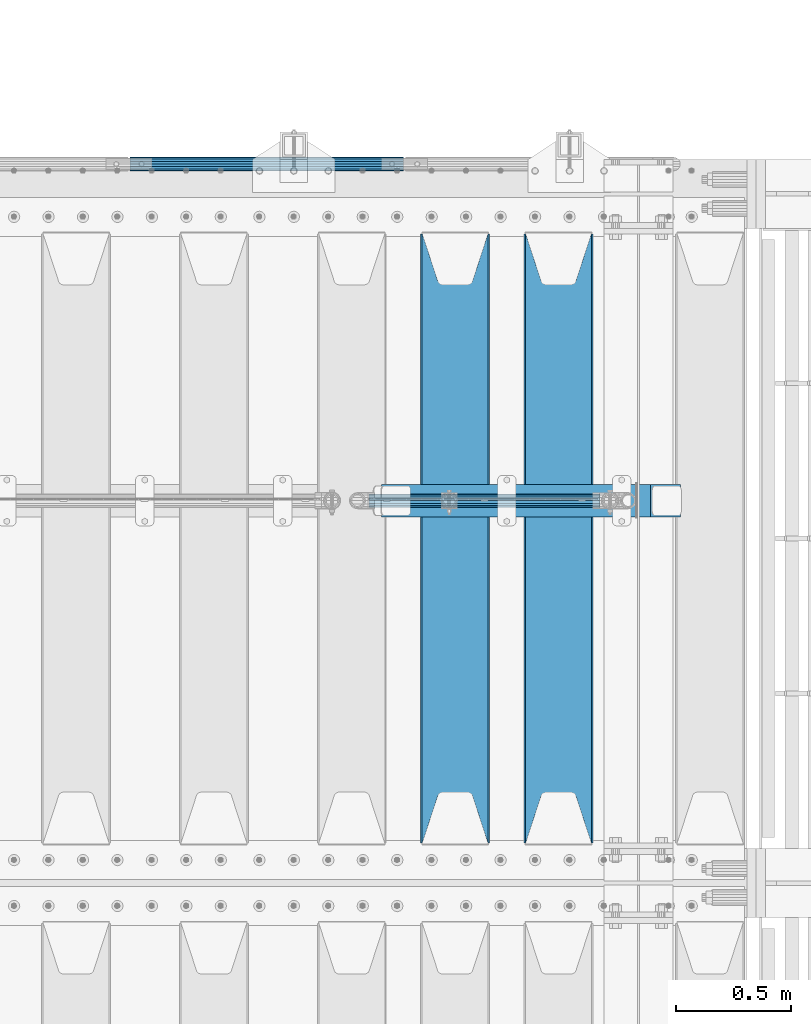
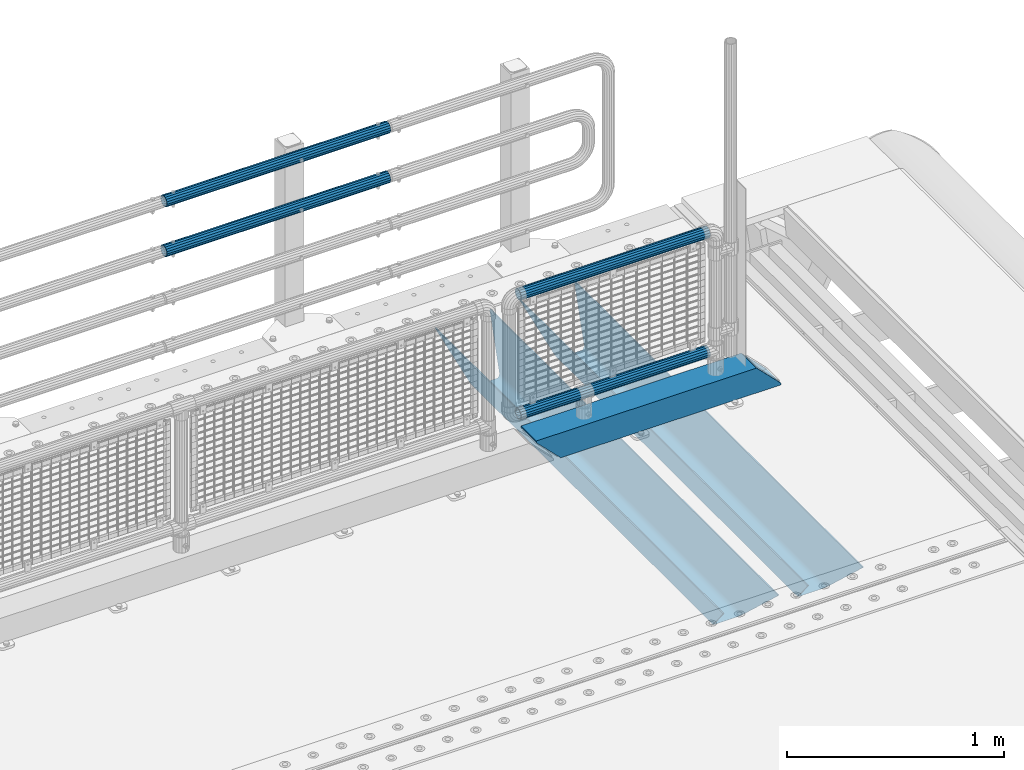
# One storey, part 148 of 270: 7 beams.
"""IFC2X3 building model written with IfcOpenShell, lengths in millimetres."""

from ifc_helpers import new_model, si_unit, frame, origin_with_axes, place, context, subcontext, project, spatial, faceted_brep, material, type_object, element, save


model = new_model("IFC2X3")

# Units and contexts
model_context = context("Model", 3, precision=1e-05, world=origin_with_axes())
body_context = subcontext(model_context, "Body", "Model", "MODEL_VIEW")
ifc_project = project(units=[si_unit("LENGTHUNIT", "METRE", prefix="MILLI"), si_unit("AREAUNIT", "SQUARE_METRE"), si_unit("VOLUMEUNIT", "CUBIC_METRE"), si_unit("MASSUNIT", "GRAM", prefix="KILO"), si_unit("TIMEUNIT", "SECOND"), si_unit("PLANEANGLEUNIT", "RADIAN"), si_unit("SOLIDANGLEUNIT", "STERADIAN"), si_unit("THERMODYNAMICTEMPERATUREUNIT", "DEGREE_CELSIUS"), si_unit("LUMINOUSINTENSITYUNIT", "LUMEN")], contexts=[model_context])

# Site, building, storey
site_placement = place(None, origin_with_axes())
site = spatial("IfcSite", under=ifc_project, at=site_placement, CompositionType="ELEMENT")
building_placement = place(site_placement, origin_with_axes())
building = spatial("IfcBuilding", under=site, at=building_placement, Name="Standard", CompositionType="ELEMENT")
storey_placement = place(building_placement, origin_with_axes())
storey = spatial("IfcBuildingStorey", under=building, at=storey_placement, Name="Undefined", CompositionType="ELEMENT", Elevation=0.0)

# Beams
ifc_material_1 = material()
beam_type_1 = type_object("IfcBeamType", PredefinedType="NOTDEFINED")
beam_1_placement = place(storey_placement, frame((17705.0000000001, -14870.1500000004, 969.549999999726), z_axis=(0.0, -1.0, 0.0), x_axis=(1.0, 0.0, 0.0)))
element("IfcBeam", 1, at=beam_1_placement, inside=storey, type_object=beam_type_1, material=ifc_material_1, context=body_context, shape_type="Brep", body=[
    faceted_brep([(0.0, -26.5499999999993, 0.0), (0.0, -24.5290015881747, 10.1602451292931), (1190.0, -24.5290015881747, 10.1602451292929), (1190.0, -26.55, 0.0), (0.0, -18.7736850405036, 18.7736850405028), (1190.0, -18.7736850405028, 18.7736850405036), (0.0, -10.1602451292929, 24.5290015881747), (1190.0, -10.1602451292931, 24.5290015881747), (0.0, 0.0, 26.55), (1190.0, 0.0, 26.5499999999993), (0.0, 10.1602451292929, 24.5290015881747), (1190.0, 10.1602451292932, 24.5290015881747), (0.0, 18.7736850405036, 18.7736850405028), (1190.0, 18.7736850405029, 18.7736850405036), (0.0, 24.5290015881747, 10.1602451292931), (1190.0, 24.5290015881747, 10.1602451292929), (0.0, 26.5499999999993, 0.0), (1190.0, 26.55, 0.0), (0.0, 24.5290015881747, -10.1602451292931), (1190.0, 24.5290015881747, -10.1602451292929), (0.0, 18.7736850405036, -18.7736850405028), (1190.0, 18.7736850405028, -18.7736850405036), (0.0, 10.1602451292929, -24.5290015881747), (1190.0, 10.1602451292931, -24.5290015881747), (0.0, 0.0, -26.55), (1190.0, 0.0, -26.5499999999993), (0.0, -10.1602451292929, -24.5290015881747), (1190.0, -10.1602451292931, -24.5290015881747), (0.0, -18.7736850405036, -18.7736850405028), (1190.0, -18.7736850405028, -18.7736850405036), (0.0, -24.5290015881747, -10.1602451292931), (1190.0, -24.5290015881747, -10.1602451292929), (0.0, -30.1499999999996, 0.0), (0.0, -27.8549679052157, -11.5379054858058), (1190.0, -27.8549679052153, -11.5379054858076), (1190.0, -30.15, 0.0), (0.0, -21.3192694527752, -21.3192694527752), (1190.0, -21.3192694527744, -21.3192694527752), (0.0, -11.5379054858076, -27.8549679052157), (1190.0, -11.5379054858075, -27.8549679052157), (0.0, 0.0, -30.1500000000015), (1190.0, 0.0, -30.1499999999996), (0.0, 11.5379054858076, -27.8549679052157), (1190.0, 11.5379054858075, -27.8549679052157), (0.0, 21.3192694527752, -21.3192694527752), (1190.0, 21.3192694527744, -21.3192694527752), (0.0, 27.8549679052157, -11.5379054858058), (1190.0, 27.8549679052153, -11.5379054858076), (0.0, 30.1499999999996, 0.0), (1190.0, 30.15, 0.0), (0.0, 27.8549679052157, 11.5379054858058), (1190.0, 27.8549679052153, 11.5379054858076), (0.0, 21.3192694527752, 21.3192694527752), (1190.0, 21.3192694527744, 21.3192694527752), (0.0, 11.5379054858076, 27.8549679052157), (1190.0, 11.5379054858075, 27.8549679052157), (0.0, 0.0, 30.1500000000015), (1190.0, 0.0, 30.1499999999996), (0.0, -11.5379054858076, 27.8549679052157), (1190.0, -11.5379054858075, 27.8549679052157), (0.0, -21.3192694527752, 21.3192694527752), (1190.0, -21.3192694527744, 21.3192694527752), (0.0, -27.8549679052157, 11.5379054858058), (1190.0, -27.8549679052153, 11.5379054858076)], [[[0, 1, 2, 3]], [[1, 4, 5, 2]], [[4, 6, 7, 5]], [[6, 8, 9, 7]], [[8, 10, 11, 9]], [[10, 12, 13, 11]], [[12, 14, 15, 13]], [[14, 16, 17, 15]], [[16, 18, 19, 17]], [[18, 20, 21, 19]], [[20, 22, 23, 21]], [[22, 24, 25, 23]], [[24, 26, 27, 25]], [[26, 28, 29, 27]], [[28, 30, 31, 29]], [[30, 0, 3, 31]], [[32, 33, 34, 35]], [[33, 36, 37, 34]], [[36, 38, 39, 37]], [[38, 40, 41, 39]], [[40, 42, 43, 41]], [[42, 44, 45, 43]], [[44, 46, 47, 45]], [[46, 48, 49, 47]], [[48, 50, 51, 49]], [[50, 52, 53, 51]], [[52, 54, 55, 53]], [[54, 56, 57, 55]], [[56, 58, 59, 57]], [[58, 60, 61, 59]], [[60, 62, 63, 61]], [[62, 32, 35, 63]], [[37, 39, 41, 43, 45, 47, 49, 51, 53, 55, 57, 59, 61, 63, 35, 34], [5, 7, 9, 11, 13, 15, 17, 19, 21, 23, 25, 27, 29, 31, 3, 2]], [[62, 60, 58, 56, 54, 52, 50, 48, 46, 44, 42, 40, 38, 36, 33, 32], [30, 28, 26, 24, 22, 20, 18, 16, 14, 12, 10, 8, 6, 4, 1, 0]]]),
])
beam_2_placement = place(storey_placement, frame((17705.0000000001, -14870.1500000004, 689.549999999726), z_axis=(0.0, -1.0, 0.0), x_axis=(1.0, 0.0, 0.0)))
element("IfcBeam", 2, at=beam_2_placement, inside=storey, type_object=beam_type_1, material=ifc_material_1, context=body_context, shape_type="Brep", body=[
    faceted_brep([(0.0, -26.5499999999993, 0.0), (0.0, -24.5290015881747, 10.1602451292931), (1190.0, -24.5290015881747, 10.1602451292929), (1190.0, -26.55, 0.0), (0.0, -18.7736850405036, 18.7736850405028), (1190.0, -18.7736850405028, 18.7736850405036), (0.0, -10.1602451292929, 24.5290015881747), (1190.0, -10.1602451292931, 24.5290015881747), (0.0, 0.0, 26.55), (1190.0, 0.0, 26.5499999999993), (0.0, 10.1602451292929, 24.5290015881747), (1190.0, 10.1602451292932, 24.5290015881747), (0.0, 18.7736850405036, 18.7736850405028), (1190.0, 18.7736850405029, 18.7736850405036), (0.0, 24.5290015881747, 10.1602451292931), (1190.0, 24.5290015881747, 10.1602451292929), (0.0, 26.5499999999993, 0.0), (1190.0, 26.55, 0.0), (0.0, 24.5290015881747, -10.1602451292931), (1190.0, 24.5290015881747, -10.1602451292929), (0.0, 18.7736850405036, -18.7736850405028), (1190.0, 18.7736850405028, -18.7736850405036), (0.0, 10.1602451292929, -24.5290015881747), (1190.0, 10.1602451292931, -24.5290015881747), (0.0, 0.0, -26.55), (1190.0, 0.0, -26.5499999999993), (0.0, -10.1602451292929, -24.5290015881747), (1190.0, -10.1602451292931, -24.5290015881747), (0.0, -18.7736850405036, -18.7736850405028), (1190.0, -18.7736850405028, -18.7736850405036), (0.0, -24.5290015881747, -10.1602451292931), (1190.0, -24.5290015881747, -10.1602451292929), (0.0, -30.1499999999996, 0.0), (0.0, -27.8549679052157, -11.5379054858058), (1190.0, -27.8549679052153, -11.5379054858076), (1190.0, -30.15, 0.0), (0.0, -21.3192694527752, -21.3192694527752), (1190.0, -21.3192694527744, -21.3192694527752), (0.0, -11.5379054858076, -27.8549679052157), (1190.0, -11.5379054858075, -27.8549679052157), (0.0, 0.0, -30.1500000000015), (1190.0, 0.0, -30.1499999999996), (0.0, 11.5379054858076, -27.8549679052157), (1190.0, 11.5379054858075, -27.8549679052157), (0.0, 21.3192694527752, -21.3192694527752), (1190.0, 21.3192694527744, -21.3192694527752), (0.0, 27.8549679052157, -11.5379054858058), (1190.0, 27.8549679052153, -11.5379054858076), (0.0, 30.1499999999996, 0.0), (1190.0, 30.15, 0.0), (0.0, 27.8549679052157, 11.5379054858058), (1190.0, 27.8549679052153, 11.5379054858076), (0.0, 21.3192694527752, 21.3192694527752), (1190.0, 21.3192694527744, 21.3192694527752), (0.0, 11.5379054858076, 27.8549679052157), (1190.0, 11.5379054858075, 27.8549679052157), (0.0, 0.0, 30.1500000000015), (1190.0, 0.0, 30.1499999999996), (0.0, -11.5379054858076, 27.8549679052157), (1190.0, -11.5379054858075, 27.8549679052157), (0.0, -21.3192694527752, 21.3192694527752), (1190.0, -21.3192694527744, 21.3192694527752), (0.0, -27.8549679052157, 11.5379054858058), (1190.0, -27.8549679052153, 11.5379054858076)], [[[0, 1, 2, 3]], [[1, 4, 5, 2]], [[4, 6, 7, 5]], [[6, 8, 9, 7]], [[8, 10, 11, 9]], [[10, 12, 13, 11]], [[12, 14, 15, 13]], [[14, 16, 17, 15]], [[16, 18, 19, 17]], [[18, 20, 21, 19]], [[20, 22, 23, 21]], [[22, 24, 25, 23]], [[24, 26, 27, 25]], [[26, 28, 29, 27]], [[28, 30, 31, 29]], [[30, 0, 3, 31]], [[32, 33, 34, 35]], [[33, 36, 37, 34]], [[36, 38, 39, 37]], [[38, 40, 41, 39]], [[40, 42, 43, 41]], [[42, 44, 45, 43]], [[44, 46, 47, 45]], [[46, 48, 49, 47]], [[48, 50, 51, 49]], [[50, 52, 53, 51]], [[52, 54, 55, 53]], [[54, 56, 57, 55]], [[56, 58, 59, 57]], [[58, 60, 61, 59]], [[60, 62, 63, 61]], [[62, 32, 35, 63]], [[37, 39, 41, 43, 45, 47, 49, 51, 53, 55, 57, 59, 61, 63, 35, 34], [5, 7, 9, 11, 13, 15, 17, 19, 21, 23, 25, 27, 29, 31, 3, 2]], [[62, 60, 58, 56, 54, 52, 50, 48, 46, 44, 42, 40, 38, 36, 33, 32], [30, 28, 26, 24, 22, 20, 18, 16, 14, 12, 10, 8, 6, 4, 1, 0]]]),
])
ifc_material_2 = material(Name="STEEL/S355N")
beam_type_2 = type_object("IfcBeamType", PredefinedType="NOTDEFINED")
beam_3_placement = place(storey_placement, frame((19570.0, -17825.0, -115.0), z_axis=(0.0, 0.0, 1.0), x_axis=(0.0, 1.0, 0.0)))
element("IfcBeam", 3, at=beam_3_placement, inside=storey, type_object=beam_type_2, material=ifc_material_2, context=body_context, shape_type="Brep", body=[
    faceted_brep([(0.0, 150.0, 115.0), (0.0, 143.689999999999, 115.0), (2650.00000000297, 143.689999999999, 115.0), (2650.00000000297, 150.0, 115.0), (2650.00000000297, 142.059565218398, 110.000000003096), (2650.00000000297, 148.3695652184, 110.000000003096), (2441.90079219209, -80.1103600731112, -98.0992078077845), (2437.7588105432, -77.5672621345584, -102.241189456673), (2434.06523489747, -74.4080125315522, -105.934765102404), (2430.9108609509, -70.710272125576, -109.089139048974), (2428.37322971128, -66.5649389910068, -111.626770288588), (2426.51472138055, -62.0739139532889, -113.485278619323), (2425.38102192092, -57.3475956567672, -114.618978078955), (2424.99999999987, -52.5021667386536, -115.0), (2424.99999999987, 52.5021667386536, -115.0), (2425.38102192092, 57.3475956567672, -114.618978078955), (2426.51472138055, 62.0739139532889, -113.485278619323), (2428.37322971128, 66.5649389910068, -111.626770288588), (2430.9108609509, 70.710272125576, -109.089139048974), (2434.06523489747, 74.4080125315522, -105.934765102404), (2437.7588105432, 77.5672621345584, -102.241189456673), (2441.90079219209, 80.1103600731112, -98.0992078077846), (2446.38936140511, 81.9747917625791, -93.6106385947584), (2448.2494850041, 76.2713538057251, -91.7505149957729), (2444.62967112263, 74.76777986261, -95.3703288772456), (2441.28936334126, 72.7168944282894, -98.710636658607), (2438.31067330439, 70.1691124903846, -101.689326695487), (2435.76682334747, 67.1870637758839, -104.233176652398), (2433.72034654133, 63.8440531834895, -106.279653458539), (2432.22154950042, 60.222258798236, -107.778450499454), (2431.30727574265, 56.4107117849089, -108.692724257221), (2430.99999999987, 52.5031078186876, -109.0), (2430.99999999987, -52.5031078186876, -109.0), (2431.30727574265, -56.4107117849089, -108.692724257221), (2432.22154950042, -60.222258798236, -107.778450499454), (2433.72034654133, -63.8440531834895, -106.279653458539), (2435.76682334747, -67.1870637758839, -104.233176652398), (2438.31067330438, -70.1691124903846, -101.689326695487), (2441.28936334126, -72.7168944282894, -98.7106366586071), (2444.62967112263, -74.76777986261, -95.3703288772457), (2448.2494850041, -76.2713538057251, -91.7505149957729), (2650.00000000297, -142.059565218398, 110.000000003096), (2650.00000000297, -148.3695652184, 110.000000003096), (2446.38936140511, -81.9747917625791, -93.6106385947584), (2650.00000000297, -143.689999999999, 115.0), (2650.00000000297, -150.0, 115.0), (0.0, -143.689999999999, 115.0), (0.0, -150.0, 115.0), (0.0, -148.369565218261, 110.000000002672), (203.610638597431, -81.9747917625791, -93.6106385947584), (208.099207810457, -80.1103600731112, -98.0992078077845), (212.241189459342, -77.5672621345584, -102.241189456673), (215.934765105078, -74.4080125315522, -105.934765102404), (219.089139051644, -70.710272125576, -109.089139048974), (221.626770291259, -66.5649389910068, -111.626770288588), (223.485278621993, -62.0739139532889, -113.485278619323), (224.618978081628, -57.3475956567672, -114.618978078955), (225.00000000267, -52.5021667386536, -115.0), (225.00000000267, 52.5021667386536, -115.0), (224.618978081628, 57.3475956567672, -114.618978078955), (223.485278621993, 62.0739139532889, -113.485278619323), (221.626770291259, 66.5649389910068, -111.626770288588), (219.089139051644, 70.710272125576, -109.089139048974), (215.934765105078, 74.4080125315522, -105.934765102404), (212.241189459342, 77.5672621345584, -102.241189456673), (208.099207810457, 80.1103600731112, -98.0992078077846), (203.610638597431, 81.9747917625791, -93.6106385947584), (0.0, 148.369565218261, 110.000000002672), (0.0, 142.05956521826, 110.000000002672), (201.750514998446, 76.2713538057251, -91.7505149957729), (205.370328879915, 74.76777986261, -95.3703288772456), (208.710636661279, 72.7168944282894, -98.710636658607), (211.689326698157, 70.1691124903846, -101.689326695487), (214.233176655071, 67.1870637758839, -104.233176652398), (216.27965346121, 63.8440531834895, -106.279653458539), (217.778450502126, 60.222258798236, -107.778450499454), (218.692724259894, 56.4107117849089, -108.692724257221), (219.00000000267, 52.5031078186876, -109.0), (219.00000000267, -52.5031078186876, -109.0), (218.692724259894, -56.4107117849089, -108.692724257221), (217.778450502123, -60.222258798236, -107.778450499454), (216.27965346121, -63.8440531834895, -106.279653458539), (214.233176655071, -67.1870637758839, -104.233176652398), (211.689326698157, -70.1691124903846, -101.689326695487), (208.710636661279, -72.7168944282894, -98.7106366586071), (205.370328879915, -74.76777986261, -95.3703288772457), (201.750514998446, -76.2713538057251, -91.7505149957729), (0.0, -142.05956521826, 110.000000002672)], [[[0, 1, 2, 3]], [[3, 2, 4, 5]], [[6, 7, 8, 9, 10, 11, 12, 13, 14, 15, 16, 17, 18, 19, 20, 21, 22, 5, 4, 23, 24, 25, 26, 27, 28, 29, 30, 31, 32, 33, 34, 35, 36, 37, 38, 39, 40, 41, 42, 43]], [[44, 45, 42, 41]], [[46, 47, 45, 44]], [[43, 42, 45, 47, 48, 49]], [[6, 43, 49, 50]], [[7, 6, 50, 51]], [[8, 7, 51, 52]], [[9, 8, 52, 53]], [[10, 9, 53, 54]], [[11, 10, 54, 55]], [[12, 11, 55, 56]], [[13, 12, 56, 57]], [[14, 13, 57, 58]], [[15, 14, 58, 59]], [[16, 15, 59, 60]], [[17, 16, 60, 61]], [[18, 17, 61, 62]], [[19, 18, 62, 63]], [[20, 19, 63, 64]], [[21, 20, 64, 65]], [[22, 21, 65, 66]], [[0, 3, 5, 22, 66, 67]], [[1, 0, 67, 68]], [[23, 4, 2, 1, 68, 69]], [[24, 23, 69, 70]], [[25, 24, 70, 71]], [[26, 25, 71, 72]], [[27, 26, 72, 73]], [[28, 27, 73, 74]], [[29, 28, 74, 75]], [[30, 29, 75, 76]], [[31, 30, 76, 77]], [[32, 31, 77, 78]], [[33, 32, 78, 79]], [[34, 33, 79, 80]], [[35, 34, 80, 81]], [[36, 35, 81, 82]], [[37, 36, 82, 83]], [[38, 37, 83, 84]], [[39, 38, 84, 85]], [[40, 39, 85, 86]], [[46, 44, 41, 40, 86, 87]], [[47, 46, 87, 48]], [[86, 85, 84, 83, 82, 81, 80, 79, 78, 77, 76, 75, 74, 73, 72, 71, 70, 69, 68, 67, 66, 65, 64, 63, 62, 61, 60, 59, 58, 57, 56, 55, 54, 53, 52, 51, 50, 49, 48, 87]]]),
])
beam_4_placement = place(storey_placement, frame((19120.0, -17825.0, -115.0), z_axis=(0.0, 0.0, 1.0), x_axis=(0.0, 1.0, 0.0)))
element("IfcBeam", 4, at=beam_4_placement, inside=storey, type_object=beam_type_2, material=ifc_material_2, context=body_context, shape_type="Brep", body=[
    faceted_brep([(0.0, 150.0, 115.0), (0.0, 143.689999999999, 115.0), (2650.00000000297, 143.689999999999, 115.0), (2650.00000000297, 150.0, 115.0), (2650.00000000297, 142.059565218398, 110.000000003096), (2650.00000000297, 148.3695652184, 110.000000003096), (2441.90079219209, -80.1103600731112, -98.0992078077845), (2437.7588105432, -77.5672621345584, -102.241189456673), (2434.06523489747, -74.4080125315522, -105.934765102404), (2430.9108609509, -70.710272125576, -109.089139048974), (2428.37322971128, -66.5649389910068, -111.626770288588), (2426.51472138055, -62.0739139532889, -113.485278619323), (2425.38102192092, -57.3475956567672, -114.618978078955), (2424.99999999987, -52.5021667386536, -115.0), (2424.99999999987, 52.5021667386536, -115.0), (2425.38102192092, 57.3475956567672, -114.618978078955), (2426.51472138055, 62.0739139532889, -113.485278619323), (2428.37322971128, 66.5649389910068, -111.626770288588), (2430.9108609509, 70.710272125576, -109.089139048974), (2434.06523489747, 74.4080125315522, -105.934765102404), (2437.7588105432, 77.5672621345584, -102.241189456673), (2441.90079219209, 80.1103600731112, -98.0992078077846), (2446.38936140511, 81.9747917625791, -93.6106385947584), (2448.2494850041, 76.2713538057251, -91.7505149957729), (2444.62967112263, 74.76777986261, -95.3703288772456), (2441.28936334126, 72.7168944282894, -98.710636658607), (2438.31067330439, 70.1691124903846, -101.689326695487), (2435.76682334747, 67.1870637758839, -104.233176652398), (2433.72034654133, 63.8440531834895, -106.279653458539), (2432.22154950042, 60.222258798236, -107.778450499454), (2431.30727574265, 56.4107117849089, -108.692724257221), (2430.99999999987, 52.5031078186876, -109.0), (2430.99999999987, -52.5031078186876, -109.0), (2431.30727574265, -56.4107117849089, -108.692724257221), (2432.22154950042, -60.222258798236, -107.778450499454), (2433.72034654133, -63.8440531834895, -106.279653458539), (2435.76682334747, -67.1870637758839, -104.233176652398), (2438.31067330438, -70.1691124903846, -101.689326695487), (2441.28936334126, -72.7168944282894, -98.7106366586071), (2444.62967112263, -74.76777986261, -95.3703288772457), (2448.2494850041, -76.2713538057251, -91.7505149957729), (2650.00000000297, -142.059565218398, 110.000000003096), (2650.00000000297, -148.3695652184, 110.000000003096), (2446.38936140511, -81.9747917625791, -93.6106385947584), (2650.00000000297, -143.689999999999, 115.0), (2650.00000000297, -150.0, 115.0), (0.0, -143.689999999999, 115.0), (0.0, -150.0, 115.0), (0.0, -148.369565218261, 110.000000002672), (203.610638597431, -81.9747917625791, -93.6106385947584), (208.099207810457, -80.1103600731112, -98.0992078077845), (212.241189459342, -77.5672621345584, -102.241189456673), (215.934765105078, -74.4080125315522, -105.934765102404), (219.089139051644, -70.710272125576, -109.089139048974), (221.626770291259, -66.5649389910068, -111.626770288588), (223.485278621993, -62.0739139532889, -113.485278619323), (224.618978081628, -57.3475956567672, -114.618978078955), (225.00000000267, -52.5021667386536, -115.0), (225.00000000267, 52.5021667386536, -115.0), (224.618978081628, 57.3475956567672, -114.618978078955), (223.485278621993, 62.0739139532889, -113.485278619323), (221.626770291259, 66.5649389910068, -111.626770288588), (219.089139051644, 70.710272125576, -109.089139048974), (215.934765105078, 74.4080125315522, -105.934765102404), (212.241189459342, 77.5672621345584, -102.241189456673), (208.099207810457, 80.1103600731112, -98.0992078077846), (203.610638597431, 81.9747917625791, -93.6106385947584), (0.0, 148.369565218261, 110.000000002672), (0.0, 142.05956521826, 110.000000002672), (201.750514998446, 76.2713538057251, -91.7505149957729), (205.370328879915, 74.76777986261, -95.3703288772456), (208.710636661279, 72.7168944282894, -98.710636658607), (211.689326698157, 70.1691124903846, -101.689326695487), (214.233176655071, 67.1870637758839, -104.233176652398), (216.27965346121, 63.8440531834895, -106.279653458539), (217.778450502126, 60.222258798236, -107.778450499454), (218.692724259894, 56.4107117849089, -108.692724257221), (219.00000000267, 52.5031078186876, -109.0), (219.00000000267, -52.5031078186876, -109.0), (218.692724259894, -56.4107117849089, -108.692724257221), (217.778450502123, -60.222258798236, -107.778450499454), (216.27965346121, -63.8440531834895, -106.279653458539), (214.233176655071, -67.1870637758839, -104.233176652398), (211.689326698157, -70.1691124903846, -101.689326695487), (208.710636661279, -72.7168944282894, -98.7106366586071), (205.370328879915, -74.76777986261, -95.3703288772457), (201.750514998446, -76.2713538057251, -91.7505149957729), (0.0, -142.05956521826, 110.000000002672)], [[[0, 1, 2, 3]], [[3, 2, 4, 5]], [[6, 7, 8, 9, 10, 11, 12, 13, 14, 15, 16, 17, 18, 19, 20, 21, 22, 5, 4, 23, 24, 25, 26, 27, 28, 29, 30, 31, 32, 33, 34, 35, 36, 37, 38, 39, 40, 41, 42, 43]], [[44, 45, 42, 41]], [[46, 47, 45, 44]], [[43, 42, 45, 47, 48, 49]], [[6, 43, 49, 50]], [[7, 6, 50, 51]], [[8, 7, 51, 52]], [[9, 8, 52, 53]], [[10, 9, 53, 54]], [[11, 10, 54, 55]], [[12, 11, 55, 56]], [[13, 12, 56, 57]], [[14, 13, 57, 58]], [[15, 14, 58, 59]], [[16, 15, 59, 60]], [[17, 16, 60, 61]], [[18, 17, 61, 62]], [[19, 18, 62, 63]], [[20, 19, 63, 64]], [[21, 20, 64, 65]], [[22, 21, 65, 66]], [[0, 3, 5, 22, 66, 67]], [[1, 0, 67, 68]], [[23, 4, 2, 1, 68, 69]], [[24, 23, 69, 70]], [[25, 24, 70, 71]], [[26, 25, 71, 72]], [[27, 26, 72, 73]], [[28, 27, 73, 74]], [[29, 28, 74, 75]], [[30, 29, 75, 76]], [[31, 30, 76, 77]], [[32, 31, 77, 78]], [[33, 32, 78, 79]], [[34, 33, 79, 80]], [[35, 34, 80, 81]], [[36, 35, 81, 82]], [[37, 36, 82, 83]], [[38, 37, 83, 84]], [[39, 38, 84, 85]], [[40, 39, 85, 86]], [[46, 44, 41, 40, 86, 87]], [[47, 46, 87, 48]], [[86, 85, 84, 83, 82, 81, 80, 79, 78, 77, 76, 75, 74, 73, 72, 71, 70, 69, 68, 67, 66, 65, 64, 63, 62, 61, 60, 59, 58, 57, 56, 55, 54, 53, 52, 51, 50, 49, 48, 87]]]),
])
beam_type_3 = type_object("IfcBeamType", PredefinedType="NOTDEFINED")
beam_5_placement = place(storey_placement, frame((18800.0, -16335.5, 98.0199999999977), z_axis=(0.0, 0.0, 1.0), x_axis=(1.0, 0.0, 0.0)))
element("IfcBeam", 5, at=beam_5_placement, inside=storey, type_object=beam_type_3, material=ifc_material_1, context=body_context, shape_type="Brep", body=[
    faceted_brep([(0.0, 70.0, 70.0), (0.0, -70.0, 70.0), (1170.88846984783, -70.0, 70.0), (1170.88846984783, 70.0, 70.0), (1301.0, -60.0, -60.0), (1301.0, 60.0, -60.0), (119.989831466442, 60.0, -60.0), (119.989910626176, -60.0, -60.0), (1180.89643628727, -60.0, 60.0), (2.49929321682885e-09, -60.0000000000073, 60.0), (2.49928966411517e-09, 59.9999999999964, 60.0), (1180.89643628727, 60.0, 60.0), (1301.0, -70.0, -60.0079600980745), (1301.0, 70.0, -60.0079600980745), (1301.0, -70.0, -70.0), (1301.0, 70.0, -70.0), (129.999907566682, 70.0, -70.0), (0.0, 70.0, 59.8689646261582), (0.0, -70.0, 59.8690568861575), (129.999999919706, -70.0, -70.0)], [[[0, 1, 2, 3]], [[4, 5, 6, 7]], [[8, 4, 7, 9]], [[9, 10, 11, 8]], [[5, 11, 10, 6]], [[2, 12, 4, 8, 11, 5, 13, 3]], [[4, 12, 14, 15, 13, 5]], [[0, 3, 13, 15, 16, 17]], [[9, 18, 1, 0, 17, 10]], [[14, 12, 2, 1, 18, 19]], [[15, 14, 19, 16]], [[18, 9, 7, 6, 10, 17, 16, 19]]]),
])
beam_type_4 = type_object("IfcBeamType", PredefinedType="NOTDEFINED")
beam_6_placement = place(storey_placement, frame((18744.6, -16335.5, 298.170000000001), z_axis=(0.0, 0.0, 1.0), x_axis=(1.0, 0.0, 0.0)))
element("IfcBeam", 6, at=beam_6_placement, inside=storey, type_object=beam_type_4, material=ifc_material_1, context=body_context, shape_type="Brep", body=[
    faceted_brep([(0.0, -25.3500000000004, 0.0), (0.0, -23.4203461491616, 9.70102501045403), (1005.0, -23.4203461491616, 9.70102501045506), (1005.0, -25.3500000000004, 0.0), (0.0, -17.9251569030785, 17.9251569030785), (1005.0, -17.9251569030785, 17.925156903079), (0.0, -9.70102501045585, 23.4203461491597), (1005.0, -9.70102501045585, 23.4203461491611), (0.0, 0.0, 25.3499999999985), (1005.0, 0.0, 25.35), (0.0, 9.70102501045585, 23.4203461491597), (1005.0, 9.70102501045585, 23.4203461491611), (0.0, 17.9251569030785, 17.9251569030785), (1005.0, 17.9251569030785, 17.925156903079), (0.0, 23.4203461491616, 9.70102501045403), (1005.0, 23.4203461491616, 9.701025010455), (0.0, 25.3500000000004, 0.0), (1005.0, 25.3500000000004, 0.0), (0.0, 23.4203461491616, -9.70102501045403), (1005.0, 23.4203461491616, -9.70102501045506), (0.0, 17.9251569030785, -17.9251569030785), (1005.0, 17.9251569030785, -17.925156903079), (0.0, 9.70102501045585, -23.4203461491597), (1005.0, 9.70102501045585, -23.4203461491611), (0.0, 0.0, -25.3499999999985), (1005.0, 0.0, -25.35), (0.0, -9.70102501045585, -23.4203461491597), (1005.0, -9.70102501045585, -23.4203461491611), (0.0, -17.9251569030785, -17.9251569030785), (1005.0, -17.9251569030785, -17.925156903079), (0.0, -23.4203461491616, -9.70102501045403), (1005.0, -23.4203461491616, -9.701025010455), (0.0, -30.1499999999996, 0.0), (0.0, -27.8549679052157, -11.5379054858058), (1005.0, -27.8549679052157, -11.5379054858075), (1005.0, -30.1499999999996, 0.0), (0.0, -21.3192694527752, -21.3192694527752), (1005.0, -21.3192694527752, -21.3192694527744), (0.0, -11.5379054858076, -27.8549679052157), (1005.0, -11.5379054858076, -27.8549679052153), (0.0, 0.0, -30.1500000000015), (1005.0, 0.0, -30.15), (0.0, 11.5379054858076, -27.8549679052157), (1005.0, 11.5379054858076, -27.8549679052153), (0.0, 21.3192694527752, -21.3192694527752), (1005.0, 21.3192694527752, -21.3192694527744), (0.0, 27.8549679052157, -11.5379054858058), (1005.0, 27.8549679052157, -11.5379054858075), (0.0, 30.1499999999996, 0.0), (1005.0, 30.1499999999996, 0.0), (0.0, 27.8549679052157, 11.5379054858058), (1005.0, 27.8549679052157, 11.5379054858075), (0.0, 21.3192694527752, 21.3192694527752), (1005.0, 21.3192694527752, 21.3192694527744), (0.0, 11.5379054858076, 27.8549679052157), (1005.0, 11.5379054858076, 27.8549679052153), (0.0, 0.0, 30.1500000000015), (1005.0, 0.0, 30.15), (0.0, -11.5379054858076, 27.8549679052157), (1005.0, -11.5379054858076, 27.8549679052153), (0.0, -21.3192694527752, 21.3192694527752), (1005.0, -21.3192694527752, 21.3192694527744), (0.0, -27.8549679052157, 11.5379054858058), (1005.0, -27.8549679052157, 11.5379054858075)], [[[0, 1, 2, 3]], [[1, 4, 5, 2]], [[4, 6, 7, 5]], [[6, 8, 9, 7]], [[8, 10, 11, 9]], [[10, 12, 13, 11]], [[12, 14, 15, 13]], [[14, 16, 17, 15]], [[16, 18, 19, 17]], [[18, 20, 21, 19]], [[20, 22, 23, 21]], [[22, 24, 25, 23]], [[24, 26, 27, 25]], [[26, 28, 29, 27]], [[28, 30, 31, 29]], [[30, 0, 3, 31]], [[32, 33, 34, 35]], [[33, 36, 37, 34]], [[36, 38, 39, 37]], [[38, 40, 41, 39]], [[40, 42, 43, 41]], [[42, 44, 45, 43]], [[44, 46, 47, 45]], [[46, 48, 49, 47]], [[48, 50, 51, 49]], [[50, 52, 53, 51]], [[52, 54, 55, 53]], [[54, 56, 57, 55]], [[56, 58, 59, 57]], [[58, 60, 61, 59]], [[60, 62, 63, 61]], [[62, 32, 35, 63]], [[37, 39, 41, 43, 45, 47, 49, 51, 53, 55, 57, 59, 61, 63, 35, 34], [5, 7, 9, 11, 13, 15, 17, 19, 21, 23, 25, 27, 29, 31, 3, 2]], [[62, 60, 58, 56, 54, 52, 50, 48, 46, 44, 42, 40, 38, 36, 33, 32], [30, 28, 26, 24, 22, 20, 18, 16, 14, 12, 10, 8, 6, 4, 1, 0]]]),
])
beam_7_placement = place(storey_placement, frame((18744.0, -16335.5, 969.85), z_axis=(0.0, 0.0, 1.0), x_axis=(1.0, 0.0, 0.0)))
element("IfcBeam", 7, at=beam_7_placement, inside=storey, type_object=beam_type_4, material=ifc_material_1, context=body_context, shape_type="Brep", body=[
    faceted_brep([(0.0, -25.3500000000004, 0.0), (0.0, -23.4203461491616, 9.70102501045403), (1005.0, -23.4203461491616, 9.70102501045506), (1005.0, -25.3500000000004, 0.0), (0.0, -17.9251569030785, 17.9251569030785), (1005.0, -17.9251569030785, 17.925156903079), (0.0, -9.70102501045585, 23.4203461491597), (1005.0, -9.70102501045585, 23.4203461491611), (0.0, 0.0, 25.3499999999985), (1005.0, 0.0, 25.35), (0.0, 9.70102501045585, 23.4203461491597), (1005.0, 9.70102501045585, 23.4203461491611), (0.0, 17.9251569030785, 17.9251569030785), (1005.0, 17.9251569030785, 17.925156903079), (0.0, 23.4203461491616, 9.70102501045403), (1005.0, 23.4203461491616, 9.701025010455), (0.0, 25.3500000000004, 0.0), (1005.0, 25.3500000000004, 0.0), (0.0, 23.4203461491616, -9.70102501045403), (1005.0, 23.4203461491616, -9.70102501045506), (0.0, 17.9251569030785, -17.9251569030785), (1005.0, 17.9251569030785, -17.925156903079), (0.0, 9.70102501045585, -23.4203461491597), (1005.0, 9.70102501045585, -23.4203461491611), (0.0, 0.0, -25.3499999999985), (1005.0, 0.0, -25.35), (0.0, -9.70102501045585, -23.4203461491597), (1005.0, -9.70102501045585, -23.4203461491611), (0.0, -17.9251569030785, -17.9251569030785), (1005.0, -17.9251569030785, -17.925156903079), (0.0, -23.4203461491616, -9.70102501045403), (1005.0, -23.4203461491616, -9.701025010455), (0.0, -30.1499999999996, 0.0), (0.0, -27.8549679052157, -11.5379054858058), (1005.0, -27.8549679052157, -11.5379054858075), (1005.0, -30.1499999999996, 0.0), (0.0, -21.3192694527752, -21.3192694527752), (1005.0, -21.3192694527752, -21.3192694527744), (0.0, -11.5379054858076, -27.8549679052157), (1005.0, -11.5379054858076, -27.8549679052153), (0.0, 0.0, -30.1500000000015), (1005.0, 0.0, -30.15), (0.0, 11.5379054858076, -27.8549679052157), (1005.0, 11.5379054858076, -27.8549679052153), (0.0, 21.3192694527752, -21.3192694527752), (1005.0, 21.3192694527752, -21.3192694527744), (0.0, 27.8549679052157, -11.5379054858058), (1005.0, 27.8549679052157, -11.5379054858075), (0.0, 30.1499999999996, 0.0), (1005.0, 30.1499999999996, 0.0), (0.0, 27.8549679052157, 11.5379054858058), (1005.0, 27.8549679052157, 11.5379054858075), (0.0, 21.3192694527752, 21.3192694527752), (1005.0, 21.3192694527752, 21.3192694527744), (0.0, 11.5379054858076, 27.8549679052157), (1005.0, 11.5379054858076, 27.8549679052153), (0.0, 0.0, 30.1500000000015), (1005.0, 0.0, 30.15), (0.0, -11.5379054858076, 27.8549679052157), (1005.0, -11.5379054858076, 27.8549679052153), (0.0, -21.3192694527752, 21.3192694527752), (1005.0, -21.3192694527752, 21.3192694527744), (0.0, -27.8549679052157, 11.5379054858058), (1005.0, -27.8549679052157, 11.5379054858075)], [[[0, 1, 2, 3]], [[1, 4, 5, 2]], [[4, 6, 7, 5]], [[6, 8, 9, 7]], [[8, 10, 11, 9]], [[10, 12, 13, 11]], [[12, 14, 15, 13]], [[14, 16, 17, 15]], [[16, 18, 19, 17]], [[18, 20, 21, 19]], [[20, 22, 23, 21]], [[22, 24, 25, 23]], [[24, 26, 27, 25]], [[26, 28, 29, 27]], [[28, 30, 31, 29]], [[30, 0, 3, 31]], [[32, 33, 34, 35]], [[33, 36, 37, 34]], [[36, 38, 39, 37]], [[38, 40, 41, 39]], [[40, 42, 43, 41]], [[42, 44, 45, 43]], [[44, 46, 47, 45]], [[46, 48, 49, 47]], [[48, 50, 51, 49]], [[50, 52, 53, 51]], [[52, 54, 55, 53]], [[54, 56, 57, 55]], [[56, 58, 59, 57]], [[58, 60, 61, 59]], [[60, 62, 63, 61]], [[62, 32, 35, 63]], [[37, 39, 41, 43, 45, 47, 49, 51, 53, 55, 57, 59, 61, 63, 35, 34], [5, 7, 9, 11, 13, 15, 17, 19, 21, 23, 25, 27, 29, 31, 3, 2]], [[62, 60, 58, 56, 54, 52, 50, 48, 46, 44, 42, 40, 38, 36, 33, 32], [30, 28, 26, 24, 22, 20, 18, 16, 14, 12, 10, 8, 6, 4, 1, 0]]]),
])

save(model, "model.ifc")
